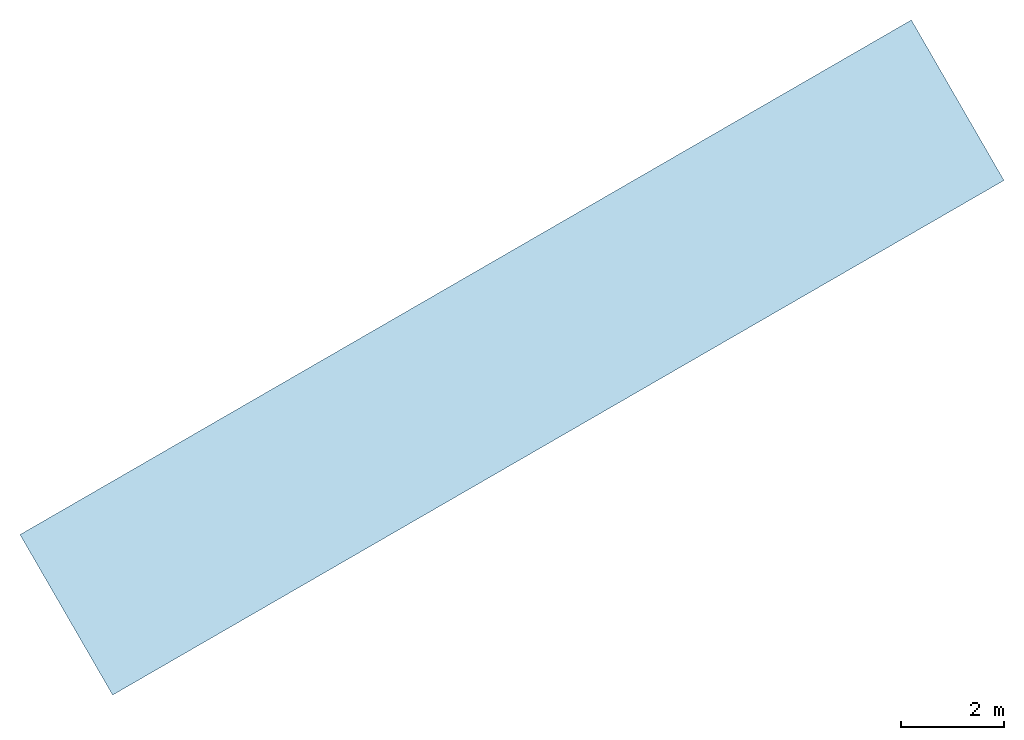
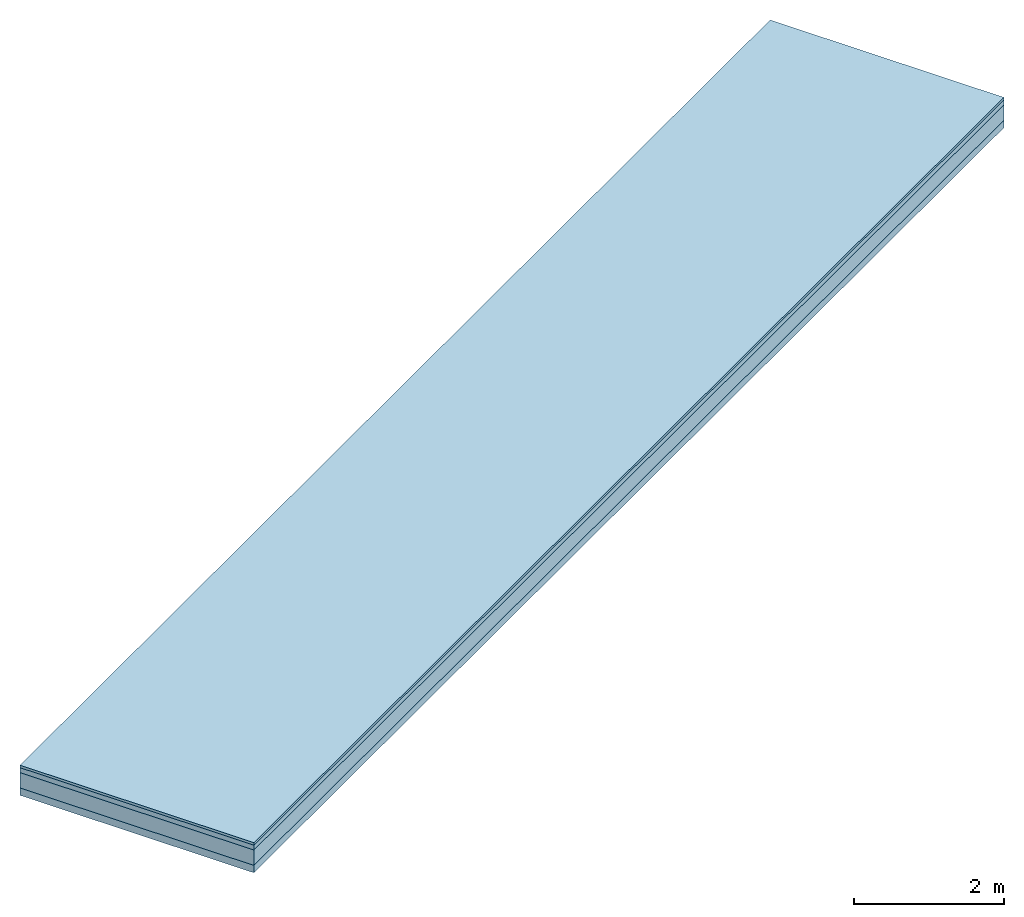
# One storey: 4 slabs.
"""IFC4 building model written with IfcOpenShell, lengths in millimetres."""

from ifc_helpers import new_model, si_unit, frame, origin_with_axes, place, context, subcontext, project, spatial, triangles, material, type_object, element, save


model = new_model("IFC4")

# Units and contexts
model_context = context("Model", 3, world=origin_with_axes())
body_context = subcontext(model_context, "Body", "Model", "MODEL_VIEW")
ifc_project = project(units=[si_unit("LENGTHUNIT", "METRE", prefix="MILLI"), si_unit("AREAUNIT", "SQUARE_METRE"), si_unit("VOLUMEUNIT", "CUBIC_METRE")], contexts=[model_context])

# Sites, buildings, storey
site_1_placement = place(None, origin_with_axes())
site_1 = spatial("IfcSite", under=ifc_project, at=site_1_placement, CompositionType="COMPLEX")
site_2_placement = place(site_1_placement, frame((1.7108101132749372e-11, 20000.000000000055, 0.0), z_axis=(0.0, 0.0, 1.0), x_axis=(-0.5000000000000002, 0.8660254037844387, 0.0)))
site_2 = spatial("IfcSite", under=site_1, at=site_2_placement, CompositionType="PARTIAL")
building_1_placement = place(site_2_placement, origin_with_axes())
building_1 = spatial("IfcBuilding", under=site_2, at=building_1_placement, Name="road parking - road", CompositionType="COMPLEX")
building_2_placement = place(building_1_placement, origin_with_axes())
building_2 = spatial("IfcBuilding", under=building_1, at=building_2_placement, Name="road parking - road segment", CompositionType="PARTIAL")
storey_placement = place(building_2_placement, origin_with_axes())
storey = spatial("IfcBuildingStorey", under=building_2, at=storey_placement, CompositionType="ELEMENT", Elevation=0.0)

# Slabs
ifc_material_1 = material(Name="bitumen_generic")
slab_type_1 = type_object("IfcSlabType", Name="road - asphalt course", PredefinedType="USERDEFINED")
slab_1_placement = place(storey_placement, frame((8.085407898761331e-11, 8.05941908765817e-09, -9.023892744153272e-14), z_axis=(0.0, 0.0, 1.0), x_axis=(1.0, 0.0, 0.0)))
element("IfcSlab", 1, at=slab_1_placement, inside=storey, type_object=slab_type_1, material=ifc_material_1, Name="road - asphalt course", ObjectType="core", context=body_context, shape_type="Tessellation", body=[
    triangles([(-1800.0000000000064, 9999.999999999904, -39.99999999999739), (-1800.0000000000064, -9999.999999999953, -119.99999999999868), (-1800.0000000000064, -9999.999999999953, -39.99999999999739), (-1800.0000000000064, 9999.999999999904, -119.99999999999868), (1800.0000000000064, -9999.999999999953, -39.99999999999739), (-1800.0000000000064, -9999.999999999953, -119.99999999999868), (1800.0000000000064, -9999.999999999953, -119.99999999999868), (-1800.0000000000064, -9999.999999999953, -39.99999999999739), (1800.0000000000064, 9999.999999999904, -119.99999999999868), (-1800.0000000000064, -9999.999999999953, -119.99999999999868), (-1800.0000000000064, 9999.999999999904, -119.99999999999868), (1800.0000000000064, -9999.999999999953, -119.99999999999868), (1800.0000000000064, 9999.999999999904, -119.99999999999868), (1800.0000000000064, -9999.999999999953, -39.99999999999739), (1800.0000000000064, -9999.999999999953, -119.99999999999868), (1800.0000000000064, 9999.999999999904, -39.99999999999739), (1800.0000000000064, -9999.999999999953, -39.99999999999739), (-1800.0000000000064, 9999.999999999904, -39.99999999999739), (-1800.0000000000064, -9999.999999999953, -39.99999999999739), (1800.0000000000064, 9999.999999999904, -39.99999999999739), (-1800.0000000000064, 9999.999999999904, -39.99999999999739), (1800.0000000000064, 9999.999999999904, -119.99999999999868), (-1800.0000000000064, 9999.999999999904, -119.99999999999868), (1800.0000000000064, 9999.999999999904, -39.99999999999739)], [[1, 2, 3], [2, 1, 4], [5, 6, 7], [6, 5, 8], [9, 10, 11], [10, 9, 12], [13, 14, 15], [14, 13, 16], [17, 18, 19], [18, 17, 20], [21, 22, 23], [22, 21, 24]]),
])
ifc_material_2 = material(Name="bitumen_asphalt_generic")
slab_type_2 = type_object("IfcSlabType", Name="road - asphalt surface course", PredefinedType="USERDEFINED")
slab_2_placement = place(storey_placement, frame((7.219114195322618e-11, 8.042093213589396e-09, -9.023892744153266e-14), z_axis=(0.0, 0.0, 1.0), x_axis=(1.0, -2.7755575615628914e-16, 0.0)))
element("IfcSlab", 2, at=slab_2_placement, inside=storey, type_object=slab_type_2, material=ifc_material_2, Name="road - asphalt surface course", ObjectType="pavement", context=body_context, shape_type="Tessellation", body=[
    triangles([(-1800.0000000000055, 9999.999999999904, 2.1657342585967822e-12), (-1799.9999999999939, -9999.999999999949, -39.999999999998074), (-1799.9999999999939, -9999.999999999949, 2.1657342585967822e-12), (-1800.0000000000055, 9999.999999999904, -39.999999999998074), (1800.0000000000025, -9999.999999999945, 2.1657342585967822e-12), (-1799.9999999999939, -9999.999999999949, -39.999999999998074), (1800.0000000000025, -9999.999999999945, -39.999999999998074), (-1799.9999999999939, -9999.999999999949, 2.1657342585967822e-12), (1800.0000000000055, 9999.999999999918, -39.999999999998074), (-1799.9999999999939, -9999.999999999949, -39.999999999998074), (-1800.0000000000055, 9999.999999999904, -39.999999999998074), (1800.0000000000025, -9999.999999999945, -39.999999999998074), (1800.0000000000055, 9999.999999999918, -39.999999999998074), (1800.0000000000025, -9999.999999999945, 2.1657342585967822e-12), (1800.0000000000025, -9999.999999999945, -39.999999999998074), (1800.0000000000055, 9999.999999999918, 2.1657342585967822e-12), (-1799.9999999999939, -9999.999999999949, 2.1657342585967822e-12), (1800.0000000000055, 9999.999999999918, 2.1657342585967822e-12), (-1800.0000000000055, 9999.999999999904, 2.1657342585967822e-12), (1800.0000000000025, -9999.999999999945, 2.1657342585967822e-12), (-1800.0000000000055, 9999.999999999904, 2.1657342585967822e-12), (1800.0000000000055, 9999.999999999918, -39.999999999998074), (-1800.0000000000055, 9999.999999999904, -39.999999999998074), (1800.0000000000055, 9999.999999999918, 2.1657342585967822e-12)], [[1, 2, 3], [2, 1, 4], [5, 6, 7], [6, 5, 8], [9, 10, 11], [10, 9, 12], [13, 14, 15], [14, 13, 16], [17, 18, 19], [18, 17, 20], [21, 22, 23], [22, 21, 24]]),
])
ifc_material_3 = material(Name="material_gravel_generic")
slab_type_3 = type_object("IfcSlabType", Name="road", PredefinedType="USERDEFINED")
slab_3_placement = place(storey_placement, frame((8.085407898761331e-11, 8.05941908765817e-09, -9.023892744153272e-14), z_axis=(0.0, 0.0, 1.0), x_axis=(1.0, -2.7755575615628914e-16, 0.0)))
element("IfcSlab", 3, at=slab_3_placement, inside=storey, type_object=slab_type_3, material=ifc_material_3, Name="road", context=body_context, shape_type="Tessellation", body=[
    triangles([(-1799.999999999983, 9999.999999999904, -119.9999999999958), (-1799.999999999986, -9999.999999999953, -369.9999999999923), (-1799.999999999986, -9999.999999999953, -119.9999999999958), (-1799.999999999983, 9999.999999999904, -369.9999999999923), (1800.0000000000177, -9999.999999999955, -119.9999999999958), (-1799.999999999986, -9999.999999999953, -369.9999999999923), (1800.0000000000177, -9999.999999999955, -369.9999999999923), (-1799.999999999986, -9999.999999999953, -119.9999999999958), (-1799.999999999983, 9999.999999999904, -369.9999999999923), (1800.0000000000177, -9999.999999999955, -369.9999999999923), (-1799.999999999986, -9999.999999999953, -369.9999999999923), (1800.0000000000148, 9999.999999999904, -369.9999999999923), (1800.0000000000148, 9999.999999999904, -369.9999999999923), (1800.0000000000177, -9999.999999999955, -119.9999999999958), (1800.0000000000177, -9999.999999999955, -369.9999999999923), (1800.0000000000148, 9999.999999999904, -119.9999999999958), (1800.0000000000177, -9999.999999999955, -119.9999999999958), (-1799.999999999983, 9999.999999999904, -119.9999999999958), (-1799.999999999986, -9999.999999999953, -119.9999999999958), (1800.0000000000148, 9999.999999999904, -119.9999999999958), (-1799.999999999983, 9999.999999999904, -119.9999999999958), (1800.0000000000148, 9999.999999999904, -369.9999999999923), (-1799.999999999983, 9999.999999999904, -369.9999999999923), (1800.0000000000148, 9999.999999999904, -119.9999999999958)], [[1, 2, 3], [2, 1, 4], [5, 6, 7], [6, 5, 8], [9, 10, 11], [10, 9, 12], [13, 14, 15], [14, 13, 16], [17, 18, 19], [18, 17, 20], [21, 22, 23], [22, 21, 24]]),
])
ifc_material_4 = material(Name="material_stone_generic")
slab_type_4 = type_object("IfcSlabType", Name="road - base course", PredefinedType="USERDEFINED")
slab_4_placement = place(storey_placement, frame((8.085407898761331e-11, 8.05941908765817e-09, -9.023892744153272e-14), z_axis=(-1.97215226305254e-31, -4.733165431326072e-30, 1.0), x_axis=(1.0, -5.551115123125783e-17, 3.94430452610506e-31)))
element("IfcSlab", 4, at=slab_4_placement, inside=storey, type_object=slab_type_4, material=ifc_material_4, Name="road - base course", context=body_context, shape_type="Tessellation", body=[
    triangles([(1800.0000000000143, -9999.999999999924, -489.99999999999505), (1800.0000000000086, 9999.999999999904, -369.9999999999922), (1800.0000000000202, -9999.999999999933, -369.99999999999216), (1800.0000000001096, 9999.99999999991, -489.99999999974716), (-1799.9999999999798, -9999.999999999909, -369.9999999999922), (1800.0000000000086, 9999.999999999904, -369.9999999999922), (-1799.9999999999854, 9999.999999999925, -369.9999999999922), (1800.0000000000202, -9999.999999999933, -369.99999999999216), (1800.0000000000202, -9999.999999999933, -369.99999999999216), (-1799.9999999999798, -9999.999999999925, -489.99999999999505), (1800.0000000000143, -9999.999999999924, -489.99999999999505), (-1799.9999999999798, -9999.999999999909, -369.9999999999922), (-1799.9999999999854, 9999.999999999925, -369.9999999999922), (1800.0000000001096, 9999.99999999991, -489.99999999974716), (-1800.0000000000837, 9999.999999999918, -489.99999999974733), (1800.0000000000086, 9999.999999999904, -369.9999999999922), (-1799.9999999999798, -9999.999999999909, -369.9999999999922), (-1800.0000000000837, 9999.999999999918, -489.99999999974733), (-1799.9999999999798, -9999.999999999925, -489.99999999999505), (-1799.9999999999854, 9999.999999999925, -369.9999999999922), (1800.0000000001096, 9999.99999999991, -489.99999999974716), (-1799.9999999999798, -9999.999999999925, -489.99999999999505), (-1800.0000000000837, 9999.999999999918, -489.99999999974733), (1800.0000000000143, -9999.999999999924, -489.99999999999505)], [[1, 2, 3], [2, 1, 4], [5, 6, 7], [6, 5, 8], [9, 10, 11], [10, 9, 12], [13, 14, 15], [14, 13, 16], [17, 18, 19], [18, 17, 20], [21, 22, 23], [22, 21, 24]]),
])

save(model, "model.ifc")
